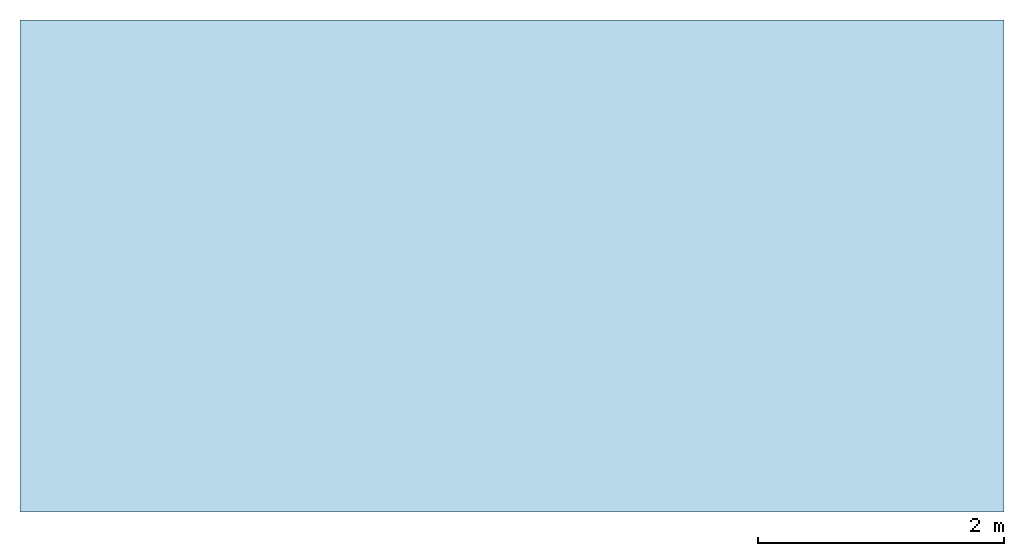
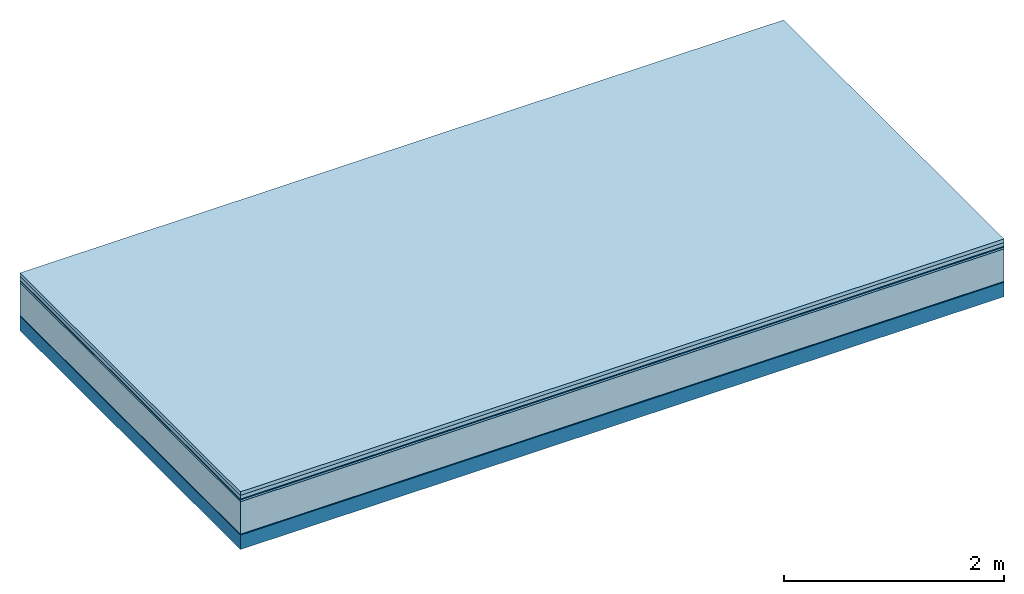
# One storey: 6 plates, 1 member, 1 element without a shape of its own.
"""IFC4 building model written with IfcOpenShell, lengths in metres."""

from ifc_helpers import new_model, si_unit, derived_unit, direction, frame, frame_2d, origin, origin_with_axes, place, context, project, spatial, rectangle, extrude, material, layer, layer_set, type_object, element, aggregate, save


model = new_model("IFC4")

# Units and contexts
plan_context = context("Plan", 3, precision=1e-05, world=origin(), true_north=direction((0.0, 1.0)))
model_context = context("Model", 3, precision=1e-05, world=origin(), true_north=direction((0.0, 1.0)))
ifc_project = project(units=[si_unit("LENGTHUNIT", "METRE"), derived_unit("SOUNDPRESSUREUNIT", [(si_unit("PRESSUREUNIT", "PASCAL", prefix="MICRO"), 0)]), si_unit("ENERGYUNIT", "JOULE", prefix="MEGA"), si_unit("MASSUNIT", "GRAM", prefix="KILO"), derived_unit("THERMALTRANSMITTANCEUNIT", [(si_unit("POWERUNIT", "WATT"), 1), (si_unit("AREAUNIT", "SQUARE_METRE"), -1), (si_unit("THERMODYNAMICTEMPERATUREUNIT", "KELVIN"), -1)]), derived_unit("AREADENSITYUNIT", [(si_unit("MASSUNIT", "GRAM", prefix="KILO"), 1), (si_unit("AREAUNIT", "SQUARE_METRE"), -1)]), derived_unit("USERDEFINED", [(si_unit("ENERGYUNIT", "JOULE", prefix="MEGA"), 1), (si_unit("AREAUNIT", "SQUARE_METRE"), -1)])], contexts=[plan_context, model_context])

# Site, building, storey
site = spatial("IfcSite", under=ifc_project)
building_placement = place(None, origin())
building = spatial("IfcBuilding", under=site, at=building_placement)
storey_placement = place(building_placement, origin())
storey = spatial("IfcBuildingStorey", under=building, at=storey_placement)

# Slab, member, plates
ifc_material_1 = material(Name="Garden plates", Category="02.007")
ifc_layer_1 = layer(ifc_material_1, 0.04, Name="Use and protection layer 3")
ifc_material_2 = material(Name="Gravel 8-16mm", Category="03.011")
ifc_layer_2 = layer(ifc_material_2, 0.04, Name="Use and protection layer 2")
ifc_material_3 = material(Name="Protective layer", Category="09.007")
ifc_layer_3 = layer(ifc_material_3, 0.01, Name="Use and protection layer 1")
ifc_material_4 = material(Name="Bituminous", Category="09.003")
ifc_layer_4 = layer(ifc_material_4, 0.02, Name="Seal")
ifc_material_5 = material(Name="Mineral wool", Category="10.008")
ifc_layer_5 = layer(ifc_material_5, 0.36, Name="Exterior insulation layer 1")
ifc_material_6 = material(Name="Vapor-permeable barrier", Category="09.006")
ifc_layer_6 = layer(ifc_material_6, 0.01, Name="layer / temporary roof")
ifc_material_7 = material(Name="no composite action")
ifc_layer_7 = layer(ifc_material_7, 0.0, Name="Bond")
ifc_layer_8 = layer(None, 0.16, Name="Support")
ifc_layer_set = layer_set([ifc_layer_1, ifc_layer_2, ifc_layer_3, ifc_layer_4, ifc_layer_5, ifc_layer_6, ifc_layer_7, ifc_layer_8])
slab_type = type_object("IfcSlabType", Name="F0052", PredefinedType="NOTDEFINED", material=ifc_layer_set)
slab_placement = place(None, frame((0.0, 0.0, 0.0), z_axis=(0.0, 0.0, -1.0), x_axis=(1.0, 0.0, 0.0)))
slab = element("IfcSlab", 1, at=slab_placement, inside=storey, type_object=slab_type, material=ifc_layer_set, Name="Slab #1")
ifc_material_8 = material(Name="Solid timber panel")
member_placement = place(slab_placement, origin())
member = element("IfcMember", 2, at=member_placement, material=ifc_material_8, Name="Support", context=plan_context, shape_type="SweptSolid", body=[
    extrude(rectangle(XDim=1.0, YDim=0.16, at=frame_2d((0.5, 0.08), x_axis=(1.0, 0.0))), frame((0.0, 4.0, 0.48), z_axis=(0.0, -1.0, 0.0), x_axis=(1.0, 0.0, 0.0)), (0.0, 0.0, 1.0), 4.0),
    extrude(rectangle(XDim=1.0, YDim=0.16, at=frame_2d((0.5, 0.08), x_axis=(1.0, 0.0))), frame((1.0, 4.0, 0.48), z_axis=(0.0, -1.0, 0.0), x_axis=(1.0, 0.0, 0.0)), (0.0, 0.0, 1.0), 4.0),
    extrude(rectangle(XDim=1.0, YDim=0.16, at=frame_2d((0.5, 0.08), x_axis=(1.0, 0.0))), frame((2.0, 4.0, 0.48), z_axis=(0.0, -1.0, 0.0), x_axis=(1.0, 0.0, 0.0)), (0.0, 0.0, 1.0), 4.0),
    extrude(rectangle(XDim=1.0, YDim=0.16, at=frame_2d((0.5, 0.08), x_axis=(1.0, 0.0))), frame((3.0, 4.0, 0.48), z_axis=(0.0, -1.0, 0.0), x_axis=(1.0, 0.0, 0.0)), (0.0, 0.0, 1.0), 4.0),
    extrude(rectangle(XDim=1.0, YDim=0.16, at=frame_2d((0.5, 0.08), x_axis=(1.0, 0.0))), frame((4.0, 4.0, 0.48), z_axis=(0.0, -1.0, 0.0), x_axis=(1.0, 0.0, 0.0)), (0.0, 0.0, 1.0), 4.0),
    extrude(rectangle(XDim=1.0, YDim=0.16, at=frame_2d((0.5, 0.08), x_axis=(1.0, 0.0))), frame((5.0, 4.0, 0.48), z_axis=(0.0, -1.0, 0.0), x_axis=(1.0, 0.0, 0.0)), (0.0, 0.0, 1.0), 4.0),
    extrude(rectangle(XDim=1.0, YDim=0.16, at=frame_2d((0.5, 0.08), x_axis=(1.0, 0.0))), frame((6.0, 4.0, 0.48), z_axis=(0.0, -1.0, 0.0), x_axis=(1.0, 0.0, 0.0)), (0.0, 0.0, 1.0), 4.0),
    extrude(rectangle(XDim=1.0, YDim=0.16, at=frame_2d((0.5, 0.08), x_axis=(1.0, 0.0))), frame((7.0, 4.0, 0.48), z_axis=(0.0, -1.0, 0.0), x_axis=(1.0, 0.0, 0.0)), (0.0, 0.0, 1.0), 4.0),
])
plate_1_placement = place(slab_placement, origin())
plate_1 = element("IfcPlate", 3, at=plate_1_placement, material=ifc_material_1, Name="Use and protection layer 3", context=plan_context, shape_type="SweptSolid", body=[
    extrude(rectangle(XDim=8.0, YDim=4.0, at=frame_2d((4.0, 2.0), x_axis=(1.0, 0.0))), origin_with_axes(), (0.0, 0.0, 1.0), 0.04),
])
plate_2_placement = place(slab_placement, origin())
plate_2 = element("IfcPlate", 4, at=plate_2_placement, material=ifc_material_2, Name="Use and protection layer 2", context=plan_context, shape_type="SweptSolid", body=[
    extrude(rectangle(XDim=8.0, YDim=4.0, at=frame_2d((4.0, 2.0), x_axis=(1.0, 0.0))), frame((0.0, 0.0, 0.04), z_axis=(0.0, 0.0, 1.0), x_axis=(1.0, 0.0, 0.0)), (0.0, 0.0, 1.0), 0.04),
])
plate_3_placement = place(slab_placement, origin())
plate_3 = element("IfcPlate", 5, at=plate_3_placement, material=ifc_material_3, Name="Use and protection layer 1", context=plan_context, shape_type="SweptSolid", body=[
    extrude(rectangle(XDim=8.0, YDim=4.0, at=frame_2d((4.0, 2.0), x_axis=(1.0, 0.0))), frame((0.0, 0.0, 0.08), z_axis=(0.0, 0.0, 1.0), x_axis=(1.0, 0.0, 0.0)), (0.0, 0.0, 1.0), 0.01),
])
plate_4_placement = place(slab_placement, origin())
plate_4 = element("IfcPlate", 6, at=plate_4_placement, material=ifc_material_4, Name="Seal", context=plan_context, shape_type="SweptSolid", body=[
    extrude(rectangle(XDim=8.0, YDim=4.0, at=frame_2d((4.0, 2.0), x_axis=(1.0, 0.0))), frame((0.0, 0.0, 0.09), z_axis=(0.0, 0.0, 1.0), x_axis=(1.0, 0.0, 0.0)), (0.0, 0.0, 1.0), 0.02),
])
plate_5_placement = place(slab_placement, origin())
plate_5 = element("IfcPlate", 7, at=plate_5_placement, material=ifc_material_5, Name="Exterior insulation layer 1", context=plan_context, shape_type="SweptSolid", body=[
    extrude(rectangle(XDim=8.0, YDim=4.0, at=frame_2d((4.0, 2.0), x_axis=(1.0, 0.0))), frame((0.0, 0.0, 0.11), z_axis=(0.0, 0.0, 1.0), x_axis=(1.0, 0.0, 0.0)), (0.0, 0.0, 1.0), 0.36),
])
plate_6_placement = place(slab_placement, origin())
plate_6 = element("IfcPlate", 8, at=plate_6_placement, material=ifc_material_6, Name="layer / temporary roof", context=plan_context, shape_type="SweptSolid", body=[
    extrude(rectangle(XDim=8.0, YDim=4.0, at=frame_2d((4.0, 2.0), x_axis=(1.0, 0.0))), frame((0.0, 0.0, 0.47), z_axis=(0.0, 0.0, 1.0), x_axis=(1.0, 0.0, 0.0)), (0.0, 0.0, 1.0), 0.01),
])
aggregate(slab, [plate_1, plate_2, plate_3, plate_4, plate_5, plate_6, member])

save(model, "model.ifc")
